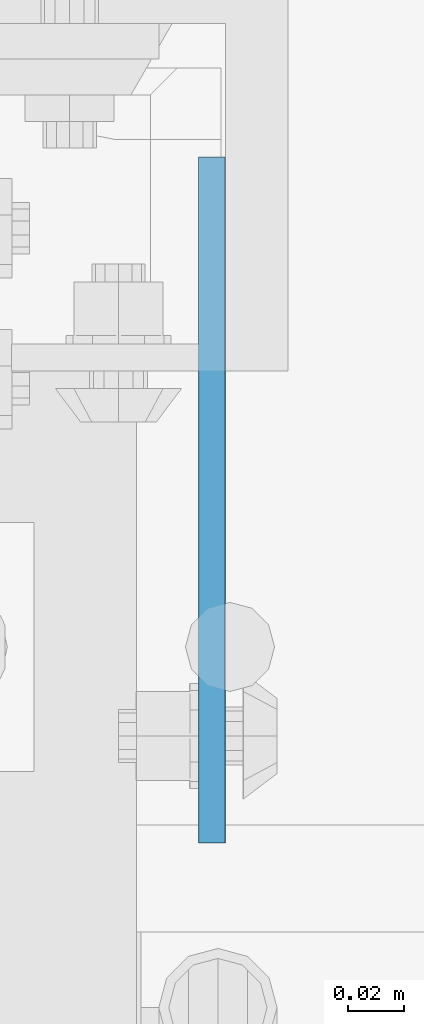
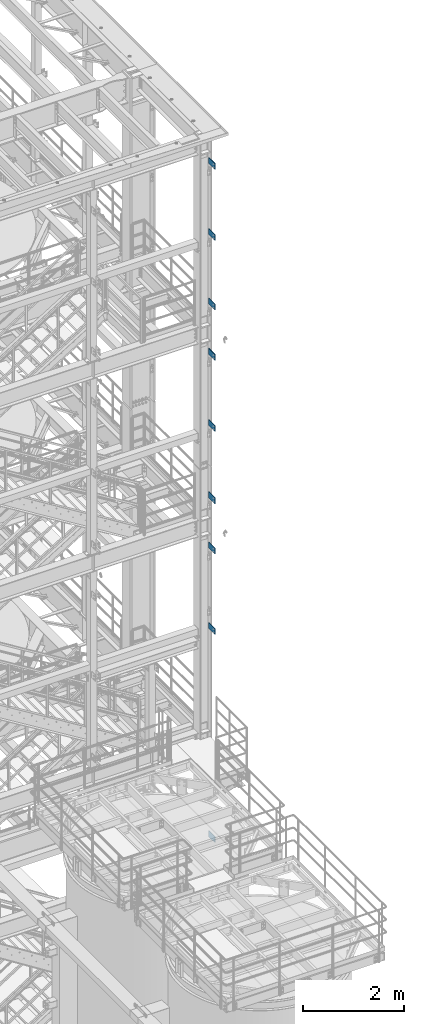
# One storey, part 1214 of 1876: 9 beams, 2 elements without a shape of their own.
"""IFC2X3 building model written with IfcOpenShell, lengths in millimetres."""

from ifc_helpers import new_model, si_unit, frame, origin_with_axes, place, context, subcontext, project, spatial, faceted_brep, material, type_object, element, aggregate, save


model = new_model("IFC2X3")

# Units and contexts
model_context = context("Model", 3, precision=1e-05, world=origin_with_axes())
body_context = subcontext(model_context, "Body", "Model", "MODEL_VIEW")
ifc_project = project(units=[si_unit("LENGTHUNIT", "METRE", prefix="MILLI"), si_unit("AREAUNIT", "SQUARE_METRE"), si_unit("VOLUMEUNIT", "CUBIC_METRE"), si_unit("MASSUNIT", "GRAM", prefix="KILO"), si_unit("TIMEUNIT", "SECOND"), si_unit("PLANEANGLEUNIT", "RADIAN"), si_unit("SOLIDANGLEUNIT", "STERADIAN"), si_unit("THERMODYNAMICTEMPERATUREUNIT", "DEGREE_CELSIUS"), si_unit("LUMINOUSINTENSITYUNIT", "LUMEN")], contexts=[model_context])

# Site, building, storey
site_placement = place(None, origin_with_axes())
site = spatial("IfcSite", under=ifc_project, at=site_placement, CompositionType="ELEMENT")
building_placement = place(site_placement, origin_with_axes())
building = spatial("IfcBuilding", under=site, at=building_placement, Name="Undefined", CompositionType="ELEMENT")
storey_placement = place(building_placement, origin_with_axes())
storey = spatial("IfcBuildingStorey", under=building, at=storey_placement, Name="Undefined", CompositionType="ELEMENT", Elevation=0.0)

# Assembly, beams
assembly_1_placement = place(storey_placement, origin_with_axes())
assembly_1 = element("IfcElementAssembly", 1, at=assembly_1_placement, inside=storey, Name="COLUMN", AssemblyPlace="NOTDEFINED", PredefinedType="RIGID_FRAME")
ifc_material = material(Name="STEEL/A36")
beam_type = type_object("IfcBeamType", PredefinedType="NOTDEFINED")
beam_1_placement = place(assembly_1_placement, frame((7727.94999357692, -7410.44999603976, 21907.5), z_axis=(0.0, 0.0, -1.0), x_axis=(0.0, 1.0, 0.0)))
beam_1 = element("IfcBeam", 2, at=beam_1_placement, type_object=beam_type, material=ifc_material, Name="PLATE", context=body_context, shape_type="Brep", body=[
    faceted_brep([(0.0, 4.76249999999982, -76.1999999999998), (3.63797880709171e-12, 4.76249999999982, 76.1999969482422), (244.474996168343, 4.76249999995889, 76.1999999999998), (244.474996168343, 4.76249999995889, -76.1999999999998), (3.63797880709171e-12, -4.76249999999982, 76.1999969482422), (244.474996168342, -4.76250000004075, 76.1999999999998), (0.0, -4.76249999999982, -76.1999999999998), (244.474996168342, -4.76250000004075, -76.1999999999998)], [[[0, 1, 2, 3]], [[1, 4, 5, 2]], [[4, 6, 7, 5]], [[6, 0, 3, 7]], [[5, 7, 3, 2]], [[6, 4, 1, 0]]]),
])
beam_2_placement = place(assembly_1_placement, frame((7727.94999357692, -7410.44999603976, 17284.7), z_axis=(0.0, 0.0, -1.0), x_axis=(0.0, 1.0, 0.0)))
beam_2 = element("IfcBeam", 3, at=beam_2_placement, type_object=beam_type, material=ifc_material, Name="PLATE", context=body_context, shape_type="Brep", body=[
    faceted_brep([(0.0, 4.76249999999982, -76.1999999999998), (3.63797880709171e-12, 4.76249999999982, 76.1999969482422), (244.474996168343, 4.76249999995889, 76.1999999999998), (244.474996168343, 4.76249999995889, -76.1999999999998), (3.63797880709171e-12, -4.76249999999982, 76.1999969482422), (244.474996168342, -4.76250000004075, 76.1999999999998), (0.0, -4.76249999999982, -76.1999999999998), (244.474996168342, -4.76250000004075, -76.1999999999998)], [[[0, 1, 2, 3]], [[1, 4, 5, 2]], [[4, 6, 7, 5]], [[6, 0, 3, 7]], [[5, 7, 3, 2]], [[6, 4, 1, 0]]]),
])

# Assembly, beam
assembly_2_placement = place(storey_placement, origin_with_axes())
assembly_2 = element("IfcElementAssembly", 4, at=assembly_2_placement, inside=storey, Name="COLUMN", AssemblyPlace="NOTDEFINED", PredefinedType="RIGID_FRAME")
beam_3_placement = place(assembly_2_placement, frame((7727.94999357692, -7410.44999603976, 12598.4), z_axis=(0.0, 0.0, -1.0), x_axis=(0.0, 1.0, 0.0)))
beam_3 = element("IfcBeam", 5, at=beam_3_placement, type_object=beam_type, material=ifc_material, Name="PLATE", context=body_context, shape_type="Brep", body=[
    faceted_brep([(0.0, 4.76249999999982, -76.1999999999998), (3.63797880709171e-12, 4.76249999999982, 76.1999969482422), (244.474996168343, 4.76249999995889, 76.1999999999998), (244.474996168343, 4.76249999995889, -76.1999999999998), (3.63797880709171e-12, -4.76249999999982, 76.1999969482422), (244.474996168342, -4.76250000004075, 76.1999999999998), (0.0, -4.76249999999982, -76.1999999999998), (244.474996168342, -4.76250000004075, -76.1999999999998)], [[[0, 1, 2, 3]], [[1, 4, 5, 2]], [[4, 6, 7, 5]], [[6, 0, 3, 7]], [[5, 7, 3, 2]], [[6, 4, 1, 0]]]),
])

# Beam
beam_4_placement = place(assembly_1_placement, frame((7727.81701010176, -7410.4499960435, 20186.65), z_axis=(0.0, 0.0, -1.0), x_axis=(0.0, 1.0, 0.0)))
beam_4 = element("IfcBeam", 6, at=beam_4_placement, type_object=beam_type, material=ifc_material, Name="PLATE", context=body_context, shape_type="Brep", body=[
    faceted_brep([(0.0, 4.76249999999982, -76.1999999999998), (3.63797880709171e-12, 4.76249999999982, 76.1999969482422), (244.474996168343, 4.76249999995889, 76.1999999999998), (244.474996168343, 4.76249999995889, -76.1999999999998), (3.63797880709171e-12, -4.76249999999982, 76.1999969482422), (244.474996168342, -4.76250000004075, 76.1999999999998), (0.0, -4.76249999999982, -76.1999999999998), (244.474996168342, -4.76250000004075, -76.1999999999998)], [[[0, 1, 2, 3]], [[1, 4, 5, 2]], [[4, 6, 7, 5]], [[6, 0, 3, 7]], [[5, 7, 3, 2]], [[6, 4, 1, 0]]]),
])

beam_5_placement = place(assembly_1_placement, frame((7727.81701010176, -7410.4499960435, 18503.9), z_axis=(0.0, 0.0, -1.0), x_axis=(0.0, 1.0, 0.0)))
beam_5 = element("IfcBeam", 7, at=beam_5_placement, type_object=beam_type, material=ifc_material, Name="PLATE", context=body_context, shape_type="Brep", body=[
    faceted_brep([(0.0, 4.76249999999982, -76.1999999999998), (3.63797880709171e-12, 4.76249999999982, 76.1999969482422), (244.474996168343, 4.76249999995889, 76.1999999999998), (244.474996168343, 4.76249999995889, -76.1999999999998), (3.63797880709171e-12, -4.76249999999982, 76.1999969482422), (244.474996168342, -4.76250000004075, 76.1999999999998), (0.0, -4.76249999999982, -76.1999999999998), (244.474996168342, -4.76250000004075, -76.1999999999998)], [[[0, 1, 2, 3]], [[1, 4, 5, 2]], [[4, 6, 7, 5]], [[6, 0, 3, 7]], [[5, 7, 3, 2]], [[6, 4, 1, 0]]]),
])

beam_6_placement = place(assembly_1_placement, frame((7727.81701010176, -7410.4499960435, 15563.85), z_axis=(0.0, 0.0, -1.0), x_axis=(0.0, 1.0, 0.0)))
beam_6 = element("IfcBeam", 8, at=beam_6_placement, type_object=beam_type, material=ifc_material, Name="PLATE", context=body_context, shape_type="Brep", body=[
    faceted_brep([(0.0, 4.76249999999982, -76.1999999999998), (3.63797880709171e-12, 4.76249999999982, 76.1999969482422), (244.474996168343, 4.76249999995889, 76.1999999999998), (244.474996168343, 4.76249999995889, -76.1999999999998), (3.63797880709171e-12, -4.76249999999982, 76.1999969482422), (244.474996168342, -4.76250000004075, 76.1999999999998), (0.0, -4.76249999999982, -76.1999999999998), (244.474996168342, -4.76250000004075, -76.1999999999998)], [[[0, 1, 2, 3]], [[1, 4, 5, 2]], [[4, 6, 7, 5]], [[6, 0, 3, 7]], [[5, 7, 3, 2]], [[6, 4, 1, 0]]]),
])

aggregate(assembly_1, [beam_1, beam_2, beam_4, beam_5, beam_6])

beam_7_placement = place(assembly_2_placement, frame((7727.81701010176, -7410.4499960435, 13817.6), z_axis=(0.0, 0.0, -1.0), x_axis=(0.0, 1.0, 0.0)))
beam_7 = element("IfcBeam", 9, at=beam_7_placement, type_object=beam_type, material=ifc_material, Name="PLATE", context=body_context, shape_type="Brep", body=[
    faceted_brep([(0.0, 4.76249999999982, -76.1999999999998), (3.63797880709171e-12, 4.76249999999982, 76.1999969482422), (244.474996168343, 4.76249999995889, 76.1999999999998), (244.474996168343, 4.76249999995889, -76.1999999999998), (3.63797880709171e-12, -4.76249999999982, 76.1999969482422), (244.474996168342, -4.76250000004075, 76.1999999999998), (0.0, -4.76249999999982, -76.1999999999998), (244.474996168342, -4.76250000004075, -76.1999999999998)], [[[0, 1, 2, 3]], [[1, 4, 5, 2]], [[4, 6, 7, 5]], [[6, 0, 3, 7]], [[5, 7, 3, 2]], [[6, 4, 1, 0]]]),
])

beam_8_placement = place(assembly_2_placement, frame((7727.81701010176, -7410.4499960435, 10648.95), z_axis=(0.0, 0.0, -1.0), x_axis=(0.0, 1.0, 0.0)))
beam_8 = element("IfcBeam", 10, at=beam_8_placement, type_object=beam_type, material=ifc_material, Name="PLATE", context=body_context, shape_type="Brep", body=[
    faceted_brep([(0.0, 4.76249999999982, -76.1999999999998), (3.63797880709171e-12, 4.76249999999982, 76.1999969482422), (244.474996168343, 4.76249999995889, 76.1999999999998), (244.474996168343, 4.76249999995889, -76.1999999999998), (3.63797880709171e-12, -4.76249999999982, 76.1999969482422), (244.474996168342, -4.76250000004075, 76.1999999999998), (0.0, -4.76249999999982, -76.1999999999998), (244.474996168342, -4.76250000004075, -76.1999999999998)], [[[0, 1, 2, 3]], [[1, 4, 5, 2]], [[4, 6, 7, 5]], [[6, 0, 3, 7]], [[5, 7, 3, 2]], [[6, 4, 1, 0]]]),
])

beam_9_placement = place(assembly_2_placement, frame((7727.81701010176, -7410.4499960435, 5613.4), z_axis=(0.0, 0.0, -1.0), x_axis=(0.0, 1.0, 0.0)))
beam_9 = element("IfcBeam", 11, at=beam_9_placement, type_object=beam_type, material=ifc_material, Name="PLATE", context=body_context, shape_type="Brep", body=[
    faceted_brep([(0.0, 4.76249999999982, -76.1999999999998), (3.63797880709171e-12, 4.76249999999982, 76.1999969482422), (244.474996168343, 4.76249999995889, 76.1999999999998), (244.474996168343, 4.76249999995889, -76.1999999999998), (3.63797880709171e-12, -4.76249999999982, 76.1999969482422), (244.474996168342, -4.76250000004075, 76.1999999999998), (0.0, -4.76249999999982, -76.1999999999998), (244.474996168342, -4.76250000004075, -76.1999999999998)], [[[0, 1, 2, 3]], [[1, 4, 5, 2]], [[4, 6, 7, 5]], [[6, 0, 3, 7]], [[5, 7, 3, 2]], [[6, 4, 1, 0]]]),
])

aggregate(assembly_2, [beam_3, beam_7, beam_8, beam_9])

save(model, "model.ifc")
